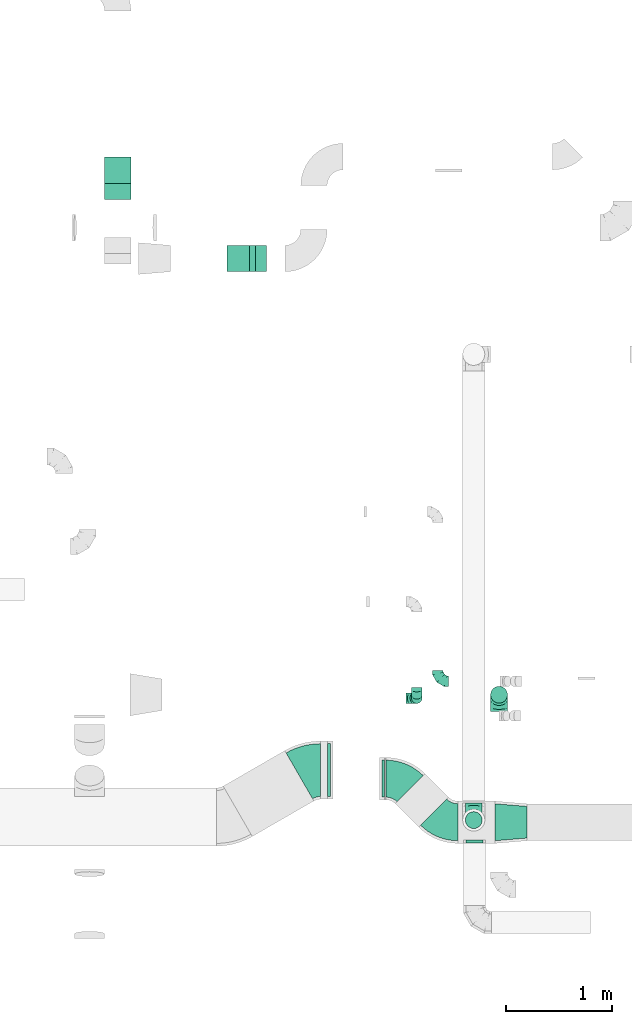
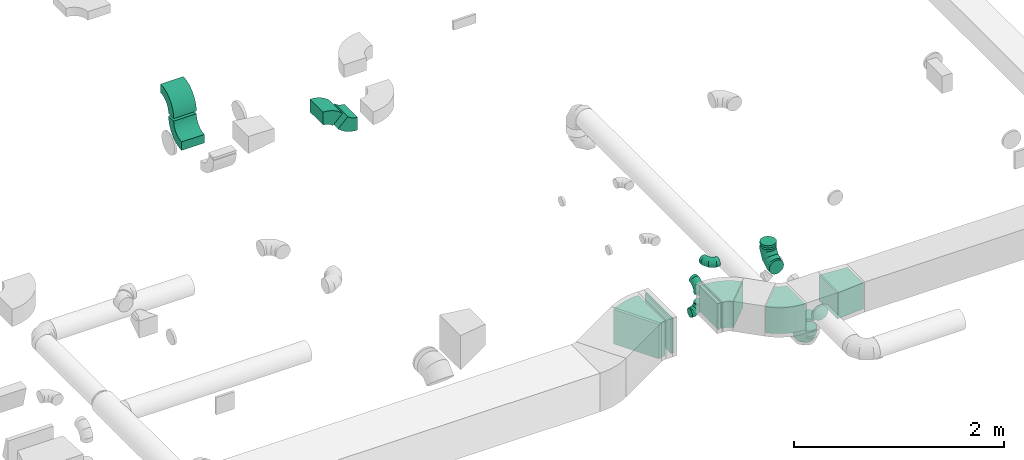
# One storey, part 47 of 62: 18 flow fittings.
"""IFC2X3 building model written with IfcOpenShell, lengths in millimetres."""

from ifc_helpers import new_model, entity, si_unit, converted_unit, derived_unit, direction, frame, frame_2d, origin, origin_2d_with_axis, place, context, subcontext, project, spatial, polyline, circle_curve, parameter, trimmed, segment, composite_curve, rectangle, outline, extrude, faceted_brep, source, transform, mapped, material, type_object, type_shapes, element, save


model = new_model("IFC2X3")

# Units and contexts
model_context = context("Model", 3, precision=0.01, world=origin(), true_north=direction((6.12303176911189e-17, 1.0)))
body_context = subcontext(model_context, "Body", "Model", "MODEL_VIEW")
ifc_project = project(units=[si_unit("LENGTHUNIT", "METRE", prefix="MILLI"), si_unit("AREAUNIT", "SQUARE_METRE"), si_unit("VOLUMEUNIT", "CUBIC_METRE"), converted_unit("PLANEANGLEUNIT", "DEGREE", entity("IfcRatioMeasure", 0.0174532925199433), si_unit("PLANEANGLEUNIT", "RADIAN"), dimensions=[0, 0, 0, 0, 0, 0, 0]), si_unit("MASSUNIT", "GRAM", prefix="KILO"), derived_unit("MASSDENSITYUNIT", [(si_unit("MASSUNIT", "GRAM", prefix="KILO"), 1), (si_unit("LENGTHUNIT", "METRE"), -3)]), derived_unit("MOMENTOFINERTIAUNIT", [(si_unit("LENGTHUNIT", "METRE"), 4)]), si_unit("TIMEUNIT", "SECOND"), si_unit("FREQUENCYUNIT", "HERTZ"), si_unit("THERMODYNAMICTEMPERATUREUNIT", "DEGREE_CELSIUS"), derived_unit("THERMALTRANSMITTANCEUNIT", [(si_unit("MASSUNIT", "GRAM", prefix="KILO"), 1), (si_unit("THERMODYNAMICTEMPERATUREUNIT", "KELVIN"), -1), (si_unit("TIMEUNIT", "SECOND"), -3)]), derived_unit("VOLUMETRICFLOWRATEUNIT", [(si_unit("LENGTHUNIT", "METRE"), 3), (si_unit("TIMEUNIT", "SECOND"), -1)]), derived_unit("MASSFLOWRATEUNIT", [(si_unit("MASSUNIT", "GRAM", prefix="KILO"), 1), (si_unit("TIMEUNIT", "SECOND"), -1)]), derived_unit("ROTATIONALFREQUENCYUNIT", [(si_unit("TIMEUNIT", "SECOND"), -1)]), si_unit("ELECTRICCURRENTUNIT", "AMPERE"), si_unit("ELECTRICVOLTAGEUNIT", "VOLT"), si_unit("POWERUNIT", "WATT"), si_unit("FORCEUNIT", "NEWTON", prefix="KILO"), si_unit("ILLUMINANCEUNIT", "LUX"), si_unit("LUMINOUSFLUXUNIT", "LUMEN"), si_unit("LUMINOUSINTENSITYUNIT", "CANDELA"), derived_unit("USERDEFINED", [(si_unit("MASSUNIT", "GRAM", prefix="KILO"), -1), (si_unit("LENGTHUNIT", "METRE"), -2), (si_unit("TIMEUNIT", "SECOND"), 3), (si_unit("LUMINOUSFLUXUNIT", "LUMEN"), 1)]), derived_unit("LINEARVELOCITYUNIT", [(si_unit("LENGTHUNIT", "METRE"), 1), (si_unit("TIMEUNIT", "SECOND"), -1)]), si_unit("PRESSUREUNIT", "PASCAL"), derived_unit("USERDEFINED", [(si_unit("LENGTHUNIT", "METRE"), -2), (si_unit("MASSUNIT", "GRAM", prefix="KILO"), 1), (si_unit("TIMEUNIT", "SECOND"), -2)]), derived_unit("LINEARFORCEUNIT", [(si_unit("MASSUNIT", "GRAM", prefix="KILO"), 1), (si_unit("LENGTHUNIT", "METRE"), 1), (si_unit("TIMEUNIT", "SECOND"), -2), (si_unit("LENGTHUNIT", "METRE"), -1)]), derived_unit("PLANARFORCEUNIT", [(si_unit("MASSUNIT", "GRAM", prefix="KILO"), 1), (si_unit("LENGTHUNIT", "METRE"), 1), (si_unit("TIMEUNIT", "SECOND"), -2), (si_unit("LENGTHUNIT", "METRE"), -2)])], contexts=[model_context])

# Site, building, storey
site_placement = place(None, origin())
site = spatial("IfcSite", under=ifc_project, at=site_placement, CompositionType="ELEMENT")
building_placement = place(site_placement, origin())
building = spatial("IfcBuilding", under=site, at=building_placement, CompositionType="ELEMENT")
storey_placement = place(building_placement, frame((0.0, 0.0, 24000.0)))
storey = spatial("IfcBuildingStorey", under=building, at=storey_placement, CompositionType="ELEMENT", Elevation=24000.0)

# Flow fittings
ifc_material = material()
duct_fitting_type_1 = type_object("IfcDuctFittingType", PredefinedType="NOTDEFINED", material=ifc_material)
shared_shape_1 = source(origin(), body_context, "Body", "SweptSolid", [
    extrude(outline(polyline([(-164.01, -161.94), (137.03, -161.94), (161.94, 137.03), (-134.95, 186.85), (-164.01, -161.94)])), frame((150.0, 0.0, -150.0), z_axis=(0.0, 0.0, 1.0), x_axis=(0.99654575824488, 0.0830454798537382, 0.0)), (0.0, 0.0, 1.0), 300.0),
])
type_shapes(duct_fitting_type_1, [shared_shape_1])
flow_fitting_1_placement = place(storey_placement, frame((60891.73, 8875.02, 3600.0)))
element("IfcFlowFitting", 1, at=flow_fitting_1_placement, inside=storey, type_object=duct_fitting_type_1, material=ifc_material, context=body_context, shape_type="MappedRepresentation", body=[
    mapped(shared_shape_1, transform((0.0, 0.0, 0.0), scale=1.0)),
])
duct_fitting_type_2 = type_object("IfcDuctFittingType", PredefinedType="NOTDEFINED", material=ifc_material)
shared_shape_2 = source(origin(), body_context, "Body", "SweptSolid", [
    extrude(rectangle(XDim=26.0960000000005, YDim=300.0, at=origin_2d_with_axis()), frame((6.95, 0.0, -175.0)), (0.0, 0.0, 1.0), 350.0),
])
type_shapes(duct_fitting_type_2, [shared_shape_2])
flow_fitting_2_placement = place(storey_placement, frame((59825.64, 9288.12, 3600.0), z_axis=(0.0, -1.0, 0.0), x_axis=(1.0, 0.0, 0.0)))
element("IfcFlowFitting", 2, at=flow_fitting_2_placement, inside=storey, type_object=duct_fitting_type_2, material=ifc_material, context=body_context, shape_type="MappedRepresentation", body=[
    mapped(shared_shape_2, transform((0.0, 0.0, 0.0), scale=1.0)),
])
duct_fitting_type_3 = type_object("IfcDuctFittingType", PredefinedType="NOTDEFINED", material=ifc_material)
shared_shape_3 = source(origin(), body_context, "Body", "SweptSolid", [
    extrude(rectangle(XDim=26.0960000000006, YDim=400.0, at=origin_2d_with_axis()), frame((6.95, 0.0, -250.0)), (0.0, 0.0, 1.0), 500.0),
])
type_shapes(duct_fitting_type_3, [shared_shape_3])
flow_fitting_3_placement = place(storey_placement, frame((59325.64, 9368.57, 3550.0), z_axis=(0.0, 1.0, 0.0), x_axis=(-1.0, 0.0, 0.0)))
element("IfcFlowFitting", 3, at=flow_fitting_3_placement, inside=storey, type_object=duct_fitting_type_3, material=ifc_material, context=body_context, shape_type="MappedRepresentation", body=[
    mapped(shared_shape_3, transform((0.0, 0.0, 0.0), scale=1.0)),
])
duct_fitting_type_4 = type_object("IfcDuctFittingType", PredefinedType="NOTDEFINED", material=ifc_material)
shared_shape_4 = source(origin(), body_context, "Body", "Brep", [
    faceted_brep([(-160.0, 0.0, -80.0), (-160.0, -20.71, -77.27), (-160.0, -40.0, -69.28), (-160.0, -56.57, -56.57), (-160.0, -69.28, -40.0), (-160.0, -77.27, -20.71), (-160.0, -80.0, 0.0), (-160.0, -77.27, 20.71), (-160.0, -69.28, 40.0), (-160.0, -56.57, 56.57), (-160.0, -40.0, 69.28), (-160.0, -20.71, 77.27), (-160.0, 0.0, 80.0), (-160.0, 20.71, 77.27), (-160.0, 40.0, 69.28), (-160.0, 56.57, 56.57), (-160.0, 69.28, 40.0), (-160.0, 77.27, 20.71), (-160.0, 80.0, 0.0), (-160.0, 77.27, -20.71), (-160.0, 69.28, -40.0), (-160.0, 56.57, -56.57), (-160.0, 40.0, -69.28), (-160.0, 20.71, -77.27), (-122.68, 20.71, 77.27), (-127.85, 40.0, 69.28), (-117.13, 0.0, 80.0), (-132.29, 56.57, 56.57), (-137.83, 77.27, 20.71), (-138.56, 80.0, 0.0), (-135.69, 69.28, 40.0), (-135.69, 69.28, -40.0), (-132.29, 56.57, -56.57), (-137.83, 77.27, -20.71), (-122.68, 20.71, -77.27), (-117.13, 0.0, -80.0), (-127.85, 40.0, -69.28), (-111.58, -20.71, -77.27), (-106.41, -40.0, -69.28), (-101.97, -56.57, -56.57), (-98.56, -69.28, -40.0), (-96.42, -77.27, -20.71), (-95.69, -80.0, 0.0), (-96.42, -77.27, 20.71), (-98.56, -69.28, 40.0), (-101.97, -56.57, 56.57), (-106.41, -40.0, 69.28), (-111.58, -20.71, 77.27), (-58.03, 58.03, 77.27), (-72.15, 72.15, 69.28), (-42.87, 42.87, 80.0), (-84.28, 84.28, 56.57), (-93.59, 93.59, 40.0), (-99.44, 99.44, 20.71), (-101.44, 101.44, 0.0), (-99.44, 99.44, -20.71), (-93.59, 93.59, -40.0), (-84.28, 84.28, -56.57), (-58.03, 58.03, -77.27), (-42.87, 42.87, -80.0), (-72.15, 72.15, -69.28), (-27.71, 27.71, -77.27), (-13.59, 13.59, -69.28), (-1.46, 1.46, -56.57), (7.85, -7.85, -40.0), (13.7, -13.7, -20.71), (15.69, -15.69, 0.0), (13.7, -13.7, 20.71), (7.85, -7.85, 40.0), (-1.46, 1.46, 56.57), (-13.59, 13.59, 69.28), (-27.71, 27.71, 77.27), (-20.71, 122.68, 77.27), (-40.0, 127.85, 69.28), (0.0, 117.13, 80.0), (-56.57, 132.29, 56.57), (-69.28, 135.69, 40.0), (-77.27, 137.83, 20.71), (-80.0, 138.56, 0.0), (-77.27, 137.83, -20.71), (-69.28, 135.69, -40.0), (-56.57, 132.29, -56.57), (-20.71, 122.68, -77.27), (0.0, 117.13, -80.0), (-40.0, 127.85, -69.28), (20.71, 111.58, -77.27), (40.0, 106.41, -69.28), (56.57, 101.97, -56.57), (69.28, 98.56, -40.0), (77.27, 96.42, -20.71), (80.0, 95.69, 0.0), (77.27, 96.42, 20.71), (69.28, 98.56, 40.0), (56.57, 101.97, 56.57), (40.0, 106.41, 69.28), (20.71, 111.58, 77.27), (-20.71, 160.0, -77.27), (-40.0, 160.0, -69.28), (-56.57, 160.0, -56.57), (-69.28, 160.0, -40.0), (-77.27, 160.0, -20.71), (-80.0, 160.0, 0.0), (-77.27, 160.0, 20.71), (-69.28, 160.0, 40.0), (-56.57, 160.0, 56.57), (-40.0, 160.0, 69.28), (-20.71, 160.0, 77.27), (0.0, 160.0, 80.0), (20.71, 160.0, 77.27), (40.0, 160.0, 69.28), (56.57, 160.0, 56.57), (69.28, 160.0, 40.0), (77.27, 160.0, 20.71), (80.0, 160.0, 0.0), (77.27, 160.0, -20.71), (69.28, 160.0, -40.0), (56.57, 160.0, -56.57), (40.0, 160.0, -69.28), (20.71, 160.0, -77.27), (0.0, 160.0, -80.0)], [[[0, 1, 2, 3, 4, 5, 6, 7, 8, 9, 10, 11, 12, 13, 14, 15, 16, 17, 18, 19, 20, 21, 22, 23]], [[24, 25, 14, 13]], [[26, 24, 13, 12]], [[14, 25, 27, 15]], [[28, 29, 18, 17]], [[30, 28, 17, 16]], [[15, 27, 30, 16]], [[20, 31, 32, 21]], [[33, 31, 20, 19]], [[18, 29, 33, 19]], [[34, 35, 0, 23]], [[36, 34, 23, 22]], [[32, 36, 22, 21]], [[1, 0, 35, 37]], [[2, 1, 37, 38]], [[3, 2, 38, 39]], [[5, 4, 40, 41]], [[6, 5, 41, 42]], [[39, 40, 4, 3]], [[6, 42, 43, 7]], [[7, 43, 44, 8]], [[8, 44, 45, 9]], [[9, 45, 46, 10]], [[10, 46, 47, 11]], [[26, 12, 11, 47]], [[48, 49, 25, 24]], [[50, 48, 24, 26]], [[27, 25, 49, 51]], [[52, 53, 28, 30]], [[51, 52, 30, 27]], [[29, 28, 53, 54]], [[55, 56, 31, 33]], [[54, 55, 33, 29]], [[32, 31, 56, 57]], [[58, 59, 35, 34]], [[60, 58, 34, 36]], [[57, 60, 36, 32]], [[37, 35, 59, 61]], [[38, 37, 61, 62]], [[39, 38, 62, 63]], [[41, 40, 64, 65]], [[42, 41, 65, 66]], [[63, 64, 40, 39]], [[43, 42, 66, 67]], [[44, 43, 67, 68]], [[68, 69, 45, 44]], [[46, 45, 69, 70]], [[47, 46, 70, 71]], [[26, 47, 71, 50]], [[72, 73, 49, 48]], [[74, 72, 48, 50]], [[51, 49, 73, 75]], [[76, 77, 53, 52]], [[75, 76, 52, 51]], [[54, 53, 77, 78]], [[79, 80, 56, 55]], [[78, 79, 55, 54]], [[57, 56, 80, 81]], [[82, 83, 59, 58]], [[84, 82, 58, 60]], [[81, 84, 60, 57]], [[61, 59, 83, 85]], [[62, 61, 85, 86]], [[63, 62, 86, 87]], [[65, 64, 88, 89]], [[66, 65, 89, 90]], [[87, 88, 64, 63]], [[67, 66, 90, 91]], [[68, 67, 91, 92]], [[92, 93, 69, 68]], [[70, 69, 93, 94]], [[71, 70, 94, 95]], [[50, 71, 95, 74]], [[96, 97, 98, 99, 100, 101, 102, 103, 104, 105, 106, 107, 108, 109, 110, 111, 112, 113, 114, 115, 116, 117, 118, 119]], [[72, 74, 107, 106]], [[73, 72, 106, 105]], [[75, 73, 105, 104]], [[77, 76, 103, 102]], [[78, 77, 102, 101]], [[75, 104, 103, 76]], [[78, 101, 100, 79]], [[79, 100, 99, 80]], [[80, 99, 98, 81]], [[84, 97, 96, 82]], [[82, 96, 119, 83]], [[84, 81, 98, 97]], [[118, 117, 86, 85]], [[119, 118, 85, 83]], [[116, 87, 86, 117]], [[88, 115, 114, 89]], [[89, 114, 113, 90]], [[115, 88, 87, 116]], [[112, 111, 92, 91]], [[113, 112, 91, 90]], [[111, 110, 93, 92]], [[95, 94, 109, 108]], [[74, 95, 108, 107]], [[110, 109, 94, 93]]]),
])
type_shapes(duct_fitting_type_4, [shared_shape_4])
for number, where, z_axis, x_axis in (
    (4, (60928.45, 10082.41, 3300.0), (1.0, 0.0, 0.0), (0.0, 1.0, 0.0)),
    (5, (60688.85, 8895.62, 3160.0), (1.0, 0.0, 0.0), (0.0, 0.0, -1.0)),
):
    element("IfcFlowFitting", number, at=place(storey_placement, frame(where, z_axis=z_axis, x_axis=x_axis)), inside=storey, type_object=duct_fitting_type_4, material=ifc_material, context=body_context, shape_type="MappedRepresentation", body=[
        mapped(shared_shape_4, transform((0.0, 0.0, 0.0), scale=1.0)),
    ])
duct_fitting_type_5 = type_object("IfcDuctFittingType", PredefinedType="NOTDEFINED", material=ifc_material)
shared_shape_5 = source(origin(), body_context, "Body", "Brep", [
    faceted_brep([(-100.0, 0.0, -50.0), (-100.0, -12.94, -48.3), (-100.0, -25.0, -43.3), (-100.0, -35.36, -35.36), (-100.0, -43.3, -25.0), (-100.0, -48.3, -12.94), (-100.0, -50.0, 0.0), (-100.0, -48.3, 12.94), (-100.0, -43.3, 25.0), (-100.0, -35.36, 35.36), (-100.0, -25.0, 43.3), (-100.0, -12.94, 48.3), (-100.0, 0.0, 50.0), (-100.0, 12.94, 48.3), (-100.0, 25.0, 43.3), (-100.0, 35.36, 35.36), (-100.0, 43.3, 25.0), (-100.0, 48.3, 12.94), (-100.0, 50.0, 0.0), (-100.0, 48.3, -12.94), (-100.0, 43.3, -25.0), (-100.0, 35.36, -35.36), (-100.0, 25.0, -43.3), (-100.0, 12.94, -48.3), (-76.67, 12.94, 48.3), (-79.9, 25.0, 43.3), (-73.21, 0.0, 50.0), (-82.68, 35.36, 35.36), (-86.15, 48.3, 12.94), (-86.6, 50.0, 0.0), (-84.81, 43.3, 25.0), (-84.81, 43.3, -25.0), (-82.68, 35.36, -35.36), (-86.15, 48.3, -12.94), (-76.67, 12.94, -48.3), (-73.21, 0.0, -50.0), (-79.9, 25.0, -43.3), (-69.74, -12.94, -48.3), (-66.51, -25.0, -43.3), (-63.73, -35.36, -35.36), (-61.6, -43.3, -25.0), (-60.26, -48.3, -12.94), (-59.81, -50.0, 0.0), (-60.26, -48.3, 12.94), (-61.6, -43.3, 25.0), (-63.73, -35.36, 35.36), (-66.51, -25.0, 43.3), (-69.74, -12.94, 48.3), (-36.27, 36.27, 48.3), (-45.1, 45.1, 43.3), (-26.79, 26.79, 50.0), (-52.68, 52.68, 35.36), (-58.49, 58.49, 25.0), (-62.15, 62.15, 12.94), (-63.4, 63.4, 0.0), (-62.15, 62.15, -12.94), (-58.49, 58.49, -25.0), (-52.68, 52.68, -35.36), (-36.27, 36.27, -48.3), (-26.79, 26.79, -50.0), (-45.1, 45.1, -43.3), (-17.32, 17.32, -48.3), (-8.49, 8.49, -43.3), (-0.91, 0.91, -35.36), (4.9, -4.9, -25.0), (8.56, -8.56, -12.94), (9.81, -9.81, 0.0), (8.56, -8.56, 12.94), (4.9, -4.9, 25.0), (-0.91, 0.91, 35.36), (-8.49, 8.49, 43.3), (-17.32, 17.32, 48.3), (-12.94, 76.67, 48.3), (-25.0, 79.9, 43.3), (0.0, 73.21, 50.0), (-35.36, 82.68, 35.36), (-43.3, 84.81, 25.0), (-48.3, 86.15, 12.94), (-50.0, 86.6, 0.0), (-48.3, 86.15, -12.94), (-43.3, 84.81, -25.0), (-35.36, 82.68, -35.36), (-12.94, 76.67, -48.3), (0.0, 73.21, -50.0), (-25.0, 79.9, -43.3), (12.94, 69.74, -48.3), (25.0, 66.51, -43.3), (35.36, 63.73, -35.36), (43.3, 61.6, -25.0), (48.3, 60.26, -12.94), (50.0, 59.81, 0.0), (48.3, 60.26, 12.94), (43.3, 61.6, 25.0), (35.36, 63.73, 35.36), (25.0, 66.51, 43.3), (12.94, 69.74, 48.3), (-12.94, 100.0, -48.3), (-25.0, 100.0, -43.3), (-35.36, 100.0, -35.36), (-43.3, 100.0, -25.0), (-48.3, 100.0, -12.94), (-50.0, 100.0, 0.0), (-48.3, 100.0, 12.94), (-43.3, 100.0, 25.0), (-35.36, 100.0, 35.36), (-25.0, 100.0, 43.3), (-12.94, 100.0, 48.3), (0.0, 100.0, 50.0), (12.94, 100.0, 48.3), (25.0, 100.0, 43.3), (35.36, 100.0, 35.36), (43.3, 100.0, 25.0), (48.3, 100.0, 12.94), (50.0, 100.0, 0.0), (48.3, 100.0, -12.94), (43.3, 100.0, -25.0), (35.36, 100.0, -35.36), (25.0, 100.0, -43.3), (12.94, 100.0, -48.3), (0.0, 100.0, -50.0)], [[[0, 1, 2, 3, 4, 5, 6, 7, 8, 9, 10, 11, 12, 13, 14, 15, 16, 17, 18, 19, 20, 21, 22, 23]], [[24, 25, 14, 13]], [[26, 24, 13, 12]], [[14, 25, 27, 15]], [[28, 29, 18, 17]], [[30, 28, 17, 16]], [[15, 27, 30, 16]], [[20, 31, 32, 21]], [[33, 31, 20, 19]], [[18, 29, 33, 19]], [[34, 35, 0, 23]], [[36, 34, 23, 22]], [[32, 36, 22, 21]], [[2, 1, 37, 38]], [[3, 2, 38, 39]], [[0, 35, 37, 1]], [[5, 4, 40, 41]], [[6, 5, 41, 42]], [[3, 39, 40, 4]], [[6, 42, 43, 7]], [[7, 43, 44, 8]], [[8, 44, 45, 9]], [[10, 46, 47, 11]], [[11, 47, 26, 12]], [[10, 9, 45, 46]], [[48, 49, 25, 24]], [[50, 48, 24, 26]], [[27, 25, 49, 51]], [[52, 53, 28, 30]], [[51, 52, 30, 27]], [[29, 28, 53, 54]], [[55, 56, 31, 33]], [[54, 55, 33, 29]], [[57, 32, 31, 56]], [[58, 59, 35, 34]], [[60, 58, 34, 36]], [[57, 60, 36, 32]], [[37, 35, 59, 61]], [[38, 37, 61, 62]], [[39, 38, 62, 63]], [[41, 40, 64, 65]], [[42, 41, 65, 66]], [[63, 64, 40, 39]], [[43, 42, 66, 67]], [[44, 43, 67, 68]], [[68, 69, 45, 44]], [[46, 45, 69, 70]], [[47, 46, 70, 71]], [[26, 47, 71, 50]], [[72, 73, 49, 48]], [[74, 72, 48, 50]], [[51, 49, 73, 75]], [[76, 77, 53, 52]], [[75, 76, 52, 51]], [[54, 53, 77, 78]], [[79, 80, 56, 55]], [[78, 79, 55, 54]], [[81, 57, 56, 80]], [[82, 83, 59, 58]], [[84, 82, 58, 60]], [[81, 84, 60, 57]], [[61, 59, 83, 85]], [[62, 61, 85, 86]], [[63, 62, 86, 87]], [[65, 64, 88, 89]], [[66, 65, 89, 90]], [[87, 88, 64, 63]], [[67, 66, 90, 91]], [[68, 67, 91, 92]], [[92, 93, 69, 68]], [[70, 69, 93, 94]], [[71, 70, 94, 95]], [[50, 71, 95, 74]], [[96, 97, 98, 99, 100, 101, 102, 103, 104, 105, 106, 107, 108, 109, 110, 111, 112, 113, 114, 115, 116, 117, 118, 119]], [[72, 74, 107, 106]], [[73, 72, 106, 105]], [[75, 73, 105, 104]], [[77, 76, 103, 102]], [[78, 77, 102, 101]], [[75, 104, 103, 76]], [[78, 101, 100, 79]], [[79, 100, 99, 80]], [[80, 99, 98, 81]], [[96, 119, 83, 82]], [[97, 96, 82, 84]], [[84, 81, 98, 97]], [[83, 119, 118, 85]], [[85, 118, 117, 86]], [[86, 117, 116, 87]], [[88, 115, 114, 89]], [[89, 114, 113, 90]], [[87, 116, 115, 88]], [[91, 90, 113, 112]], [[92, 91, 112, 111]], [[93, 92, 111, 110]], [[95, 94, 109, 108]], [[74, 95, 108, 107]], [[110, 109, 94, 93]]]),
])
type_shapes(duct_fitting_type_5, [shared_shape_5])
for number, where, z_axis, x_axis in (
    (6, (60349.74, 10209.98, 3360.0), (0.0, 0.0, 1.0), (0.0, -1.0, 0.0)),
    (7, (60149.52, 10049.93, 3000.0), (0.0, -1.0, 0.0), (1.0, 0.0, 0.0)),
    (8, (60149.52, 10049.93, 3300.0), (-1.0, 0.0, 0.0), (0.0, 0.0, 1.0)),
):
    element("IfcFlowFitting", number, at=place(storey_placement, frame(where, z_axis=z_axis, x_axis=x_axis)), inside=storey, type_object=duct_fitting_type_5, material=ifc_material, context=body_context, shape_type="MappedRepresentation", body=[
        mapped(shared_shape_5, transform((0.0, 0.0, 0.0), scale=1.0)),
    ])
duct_fitting_type_6 = type_object("IfcDuctFittingType", PredefinedType="NOTDEFINED", material=ifc_material)
shared_shape_6 = source(origin(), body_context, "Body", "Brep", [
    faceted_brep([(20.0, 0.0, -80.0), (20.0, 20.71, -77.27), (20.0, 40.0, -69.28), (20.0, 56.57, -56.57), (20.0, 69.28, -40.0), (20.0, 77.27, -20.71), (20.0, 80.0, 0.0), (20.0, 77.27, 20.71), (20.0, 69.28, 40.0), (20.0, 56.57, 56.57), (20.0, 40.0, 69.28), (20.0, 20.71, 77.27), (20.0, 0.0, 80.0), (20.0, -20.71, 77.27), (20.0, -40.0, 69.28), (20.0, -56.57, 56.57), (20.0, -69.28, 40.0), (20.0, -77.27, 20.71), (20.0, -80.0, 0.0), (20.0, -77.27, -20.71), (20.0, -69.28, -40.0), (20.0, -56.57, -56.57), (20.0, -40.0, -69.28), (20.0, -20.71, -77.27), (0.0, 0.0, 80.0), (-6.1, 0.0, 80.0), (-6.1, -20.71, 77.27), (0.0, -20.71, 77.27), (-6.1, -40.0, 69.28), (0.0, -40.0, 69.28), (0.0, -56.57, 56.57), (-6.1, -56.57, 56.57), (0.0, -69.28, 40.0), (-6.1, -69.28, 40.0), (-6.1, -77.27, 20.71), (0.0, -77.27, 20.71), (-6.1, -80.0, 0.0), (0.0, -80.0, 0.0), (-6.1, -77.27, -20.71), (0.0, -77.27, -20.71), (-6.1, -69.28, -40.0), (0.0, -69.28, -40.0), (0.0, -56.57, -56.57), (-6.1, -56.57, -56.57), (0.0, -40.0, -69.28), (-6.1, -40.0, -69.28), (-6.1, -20.71, -77.27), (0.0, -20.71, -77.27), (-6.1, 0.0, -80.0), (0.0, 0.0, -80.0), (-6.1, 20.71, -77.27), (0.0, 20.71, -77.27), (-6.1, 40.0, -69.28), (0.0, 40.0, -69.28), (0.0, 56.57, -56.57), (-6.1, 56.57, -56.57), (0.0, 69.28, -40.0), (-6.1, 69.28, -40.0), (-6.1, 77.27, -20.71), (0.0, 77.27, -20.71), (-6.1, 80.0, 0.0), (0.0, 80.0, 0.0), (-6.1, 77.27, 20.71), (0.0, 77.27, 20.71), (-6.1, 69.28, 40.0), (0.0, 69.28, 40.0), (0.0, 56.57, 56.57), (-6.1, 56.57, 56.57), (0.0, 40.0, 69.28), (-6.1, 40.0, 69.28), (-6.1, 20.71, 77.27), (0.0, 20.71, 77.27)], [[[0, 1, 2, 3, 4, 5, 6, 7, 8, 9, 10, 11, 12, 13, 14, 15, 16, 17, 18, 19, 20, 21, 22, 23]], [[13, 12, 24, 25, 26, 27]], [[14, 13, 27, 26, 28, 29]], [[30, 15, 14, 29, 28, 31]], [[17, 16, 32, 33, 34, 35]], [[18, 17, 35, 34, 36, 37]], [[32, 16, 15, 30, 31, 33]], [[19, 18, 37, 36, 38, 39]], [[20, 19, 39, 38, 40, 41]], [[42, 21, 20, 41, 40, 43]], [[23, 22, 44, 45, 46, 47]], [[0, 23, 47, 46, 48, 49]], [[44, 22, 21, 42, 43, 45]], [[1, 0, 49, 48, 50, 51]], [[2, 1, 51, 50, 52, 53]], [[54, 3, 2, 53, 52, 55]], [[5, 4, 56, 57, 58, 59]], [[6, 5, 59, 58, 60, 61]], [[56, 4, 3, 54, 55, 57]], [[7, 6, 61, 60, 62, 63]], [[8, 7, 63, 62, 64, 65]], [[66, 9, 8, 65, 64, 67]], [[11, 10, 68, 69, 70, 71]], [[12, 11, 71, 70, 25, 24]], [[68, 10, 9, 66, 67, 69]], [[46, 45, 43, 40, 38, 36, 34, 33, 31, 28, 26, 25, 70, 69, 67, 64, 62, 60, 58, 57, 55, 52, 50, 48]]]),
])
type_shapes(duct_fitting_type_6, [shared_shape_6])
for number, where, z_axis, x_axis in (
    (9, (60928.45, 10082.41, 3500.0), (0.0, -1.0, 0.0), (0.0, 0.0, -1.0)),
    (10, (60696.21, 8700.02, 3600.0), (0.0, 0.0, -1.0), (0.0, -1.0, 0.0)),
):
    element("IfcFlowFitting", number, at=place(storey_placement, frame(where, z_axis=z_axis, x_axis=x_axis)), inside=storey, type_object=duct_fitting_type_6, material=ifc_material, context=body_context, shape_type="MappedRepresentation", body=[
        mapped(shared_shape_6, transform((0.0, 0.0, 0.0), scale=1.0)),
    ])
duct_fitting_type_7 = type_object("IfcDuctFittingType", PredefinedType="NOTDEFINED", material=ifc_material)
shared_shape_7 = source(origin(), body_context, "Body", "Brep", [
    faceted_brep([(20.0, 20.71, -77.27), (20.0, 40.0, -69.28), (20.0, 56.57, -56.57), (20.0, 69.28, -40.0), (20.0, 77.27, -20.71), (20.0, 80.0, 0.0), (20.0, 77.27, 20.71), (20.0, 69.28, 40.0), (20.0, 56.57, 56.57), (20.0, 40.0, 69.28), (20.0, 20.71, 77.27), (20.0, 0.0, 80.0), (20.0, -20.71, 77.27), (20.0, -40.0, 69.28), (20.0, -56.57, 56.57), (20.0, -69.28, 40.0), (20.0, -77.27, 20.71), (20.0, -80.0, 0.0), (20.0, -77.27, -20.71), (20.0, -69.28, -40.0), (20.0, -56.57, -56.57), (20.0, -40.0, -69.28), (20.0, -20.71, -77.27), (20.0, 0.0, -80.0), (0.0, 0.0, 80.0), (0.0, 20.71, 77.27), (-6.1, 20.71, 77.27), (-6.1, 0.0, 80.0), (0.0, 40.0, 69.28), (-6.1, 40.0, 69.28), (0.0, 56.57, 56.57), (-6.1, 56.57, 56.57), (0.0, 69.28, 40.0), (0.0, 77.27, 20.71), (-6.1, 77.27, 20.71), (-6.1, 69.28, 40.0), (0.0, 80.0, 0.0), (-6.1, 80.0, 0.0), (0.0, 77.27, -20.71), (-6.1, 77.27, -20.71), (0.0, 69.28, -40.0), (-6.1, 69.28, -40.0), (0.0, 56.57, -56.57), (-6.1, 56.57, -56.57), (0.0, 40.0, -69.28), (0.0, 20.71, -77.27), (-6.1, 20.71, -77.27), (-6.1, 40.0, -69.28), (0.0, 0.0, -80.0), (-6.1, 0.0, -80.0), (0.0, -20.71, -77.27), (-6.1, -20.71, -77.27), (0.0, -40.0, -69.28), (-6.1, -40.0, -69.28), (0.0, -56.57, -56.57), (-6.1, -56.57, -56.57), (0.0, -69.28, -40.0), (0.0, -77.27, -20.71), (-6.1, -77.27, -20.71), (-6.1, -69.28, -40.0), (0.0, -80.0, 0.0), (-6.1, -80.0, 0.0), (0.0, -77.27, 20.71), (-6.1, -77.27, 20.71), (0.0, -69.28, 40.0), (-6.1, -69.28, 40.0), (0.0, -56.57, 56.57), (-6.1, -56.57, 56.57), (0.0, -40.0, 69.28), (0.0, -20.71, 77.27), (-6.1, -20.71, 77.27), (-6.1, -40.0, 69.28)], [[[0, 1, 2, 3, 4, 5, 6, 7, 8, 9, 10, 11, 12, 13, 14, 15, 16, 17, 18, 19, 20, 21, 22, 23]], [[24, 11, 10, 25, 26, 27]], [[25, 10, 9, 28, 29, 26]], [[28, 9, 8, 30, 31, 29]], [[32, 7, 6, 33, 34, 35]], [[33, 6, 5, 36, 37, 34]], [[30, 8, 7, 32, 35, 31]], [[36, 5, 4, 38, 39, 37]], [[38, 4, 3, 40, 41, 39]], [[40, 3, 2, 42, 43, 41]], [[44, 1, 0, 45, 46, 47]], [[45, 0, 23, 48, 49, 46]], [[42, 2, 1, 44, 47, 43]], [[48, 23, 22, 50, 51, 49]], [[50, 22, 21, 52, 53, 51]], [[52, 21, 20, 54, 55, 53]], [[56, 19, 18, 57, 58, 59]], [[57, 18, 17, 60, 61, 58]], [[54, 20, 19, 56, 59, 55]], [[60, 17, 16, 62, 63, 61]], [[62, 16, 15, 64, 65, 63]], [[64, 15, 14, 66, 67, 65]], [[68, 13, 12, 69, 70, 71]], [[69, 12, 11, 24, 27, 70]], [[66, 14, 13, 68, 71, 67]], [[49, 51, 53, 55, 59, 58, 61, 63, 65, 67, 71, 70, 27, 26, 29, 31, 35, 34, 37, 39, 41, 43, 47, 46]]]),
])
type_shapes(duct_fitting_type_7, [shared_shape_7])
flow_fitting_4_placement = place(storey_placement, frame((60688.85, 8895.62, 3450.0), z_axis=(0.0, -1.0, 0.0), x_axis=(0.0, 0.0, -1.0)))
element("IfcFlowFitting", 11, at=flow_fitting_4_placement, inside=storey, type_object=duct_fitting_type_7, material=ifc_material, context=body_context, shape_type="MappedRepresentation", body=[
    mapped(shared_shape_7, transform((0.0, 0.0, 0.0), scale=1.0)),
])
duct_fitting_type_8 = type_object("IfcDuctFittingType", PredefinedType="NOTDEFINED", material=ifc_material)
shared_shape_8 = source(origin(), body_context, "Body", "SweptSolid", [
    extrude(outline(composite_curve([segment(polyline([(-107.95, -79.55), (42.05, -79.55)]), True, "CONTINUOUS"), segment(trimmed(circle_curve(frame_2d((192.05, -79.55), x_axis=(-0.707106781186546, 0.707106781186546)), 150.0), [parameter(0.0)], [parameter(45.0)], True, "PARAMETER"), False, "CONTINUOUS"), segment(polyline([(85.98, 26.52), (-20.08, 132.58)]), True, "CONTINUOUS"), segment(trimmed(circle_curve(frame_2d((192.05, -79.55), x_axis=(-0.707106781186546, 0.707106781186546)), 300.0), [parameter(0.0)], [parameter(45.0)], True, "PARAMETER"), True, "CONTINUOUS")], self_intersect=False)), frame((-13.65, 32.95, -125.0), z_axis=(0.0, 0.0, 1.0), x_axis=(-0.707106781186547, 0.707106781186548, 0.0)), (0.0, 0.0, 1.0), 250.0),
])
type_shapes(duct_fitting_type_8, [shared_shape_8])
for number, where, z_axis, x_axis in (
    (12, (58445.82, 14212.02, 3400.0), (0.0, 1.0, 0.0), (1.0, 0.0, 0.0)),
    (13, (58635.82, 14212.02, 3210.0), (0.0, -1.0, 0.0), (0.707106781186271, 0.0, -0.707106781186824)),
):
    element("IfcFlowFitting", number, at=place(storey_placement, frame(where, z_axis=z_axis, x_axis=x_axis)), inside=storey, type_object=duct_fitting_type_8, material=ifc_material, context=body_context, shape_type="MappedRepresentation", body=[
        mapped(shared_shape_8, transform((0.0, 0.0, 0.0), scale=1.0)),
    ])
duct_fitting_type_9 = type_object("IfcDuctFittingType", PredefinedType="NOTDEFINED", material=ifc_material)
shared_shape_9 = source(origin(), body_context, "Body", "SweptSolid", [
    extrude(outline(composite_curve([segment(polyline([(-150.0, -100.0), (-50.0, -100.0)]), True, "CONTINUOUS"), segment(trimmed(circle_curve(frame_2d((100.0, -100.0), x_axis=(0.0, 1.0)), 150.0), [parameter(0.0)], [parameter(90.0000000000001)], True, "PARAMETER"), False, "CONTINUOUS"), segment(polyline([(100.0, 50.0), (100.0, 150.0)]), True, "CONTINUOUS"), segment(trimmed(circle_curve(frame_2d((100.0, -100.0), x_axis=(0.0, 1.0)), 250.0), [parameter(0.0)], [parameter(90.0000000000001)], True, "PARAMETER"), True, "CONTINUOUS")], self_intersect=False)), frame((-100.0, 100.0, -125.0), z_axis=(0.0, 0.0, 1.0), x_axis=(-1.0, 0.0, 0.0)), (0.0, 0.0, 1.0), 250.0),
])
type_shapes(duct_fitting_type_9, [shared_shape_9])
for number, where, z_axis, x_axis in (
    (14, (57317.89, 14972.02, 3500.0), (1.0, 0.0, 0.0), (0.0, -1.0, 0.0)),
    (15, (57317.89, 14972.02, 3070.0), (-1.0, 0.0, 0.0), (0.0, 0.0, -1.0)),
):
    element("IfcFlowFitting", number, at=place(storey_placement, frame(where, z_axis=z_axis, x_axis=x_axis)), inside=storey, type_object=duct_fitting_type_9, material=ifc_material, context=body_context, shape_type="MappedRepresentation", body=[
        mapped(shared_shape_9, transform((0.0, 0.0, 0.0), scale=1.0)),
    ])
duct_fitting_type_10 = type_object("IfcDuctFittingType", PredefinedType="NOTDEFINED", material=ifc_material)
shared_shape_10 = source(origin(), body_context, "Body", "SweptSolid", [
    extrude(outline(composite_curve([segment(polyline([(-276.79, -100.0), (223.21, -100.0)]), True, "CONTINUOUS"), segment(trimmed(circle_curve(frame_2d((373.21, -100.0), x_axis=(-0.866025403784437, 0.499999999999998)), 150.0), [parameter(0.0)], [parameter(29.9999999999999)], True, "PARAMETER"), False, "CONTINUOUS"), segment(polyline([(243.3, -25.0), (-189.71, 225.0)]), True, "CONTINUOUS"), segment(trimmed(circle_curve(frame_2d((373.21, -100.0), x_axis=(-0.866025403784437, 0.499999999999998)), 650.0), [parameter(0.0)], [parameter(29.9999999999999)], True, "PARAMETER"), True, "CONTINUOUS")], self_intersect=False)), frame((-7.18, 26.79, -200.0), z_axis=(0.0, 0.0, 1.0), x_axis=(-0.499999999999999, 0.866025403784439, 0.0)), (0.0, 0.0, 1.0), 400.0),
])
type_shapes(duct_fitting_type_10, [shared_shape_10])
flow_fitting_5_placement = place(storey_placement, frame((59130.06, 9368.57, 3550.0), z_axis=(0.0, 0.0, 1.0), x_axis=(-1.0, 0.0, 0.0)))
element("IfcFlowFitting", 16, at=flow_fitting_5_placement, inside=storey, type_object=duct_fitting_type_10, material=ifc_material, context=body_context, shape_type="MappedRepresentation", body=[
    mapped(shared_shape_10, transform((0.0, 0.0, 0.0), scale=1.0)),
])
duct_fitting_type_11 = type_object("IfcDuctFittingType", PredefinedType="NOTDEFINED", material=ifc_material)
shared_shape_11 = source(origin(), body_context, "Body", "SweptSolid", [
    extrude(outline(composite_curve([segment(polyline([(-222.6, -114.9), (127.4, -114.9)]), True, "CONTINUOUS"), segment(trimmed(circle_curve(frame_2d((277.4, -114.9), x_axis=(-0.707106781186553, 0.707106781186546)), 150.0), [parameter(0.0)], [parameter(45.0)], True, "PARAMETER"), False, "CONTINUOUS"), segment(polyline([(171.34, -8.84), (-76.15, 238.65)]), True, "CONTINUOUS"), segment(trimmed(circle_curve(frame_2d((277.4, -114.9), x_axis=(-0.707106781186553, 0.707106781186546)), 500.0), [parameter(0.0)], [parameter(45.0)], True, "PARAMETER"), True, "CONTINUOUS")], self_intersect=False)), frame((-19.71, 47.6, -150.0), z_axis=(0.0, 0.0, 1.0), x_axis=(-0.707106781186547, 0.707106781186548, 0.0)), (0.0, 0.0, 1.0), 300.0),
])
type_shapes(duct_fitting_type_11, [shared_shape_11])
for number, where, z_axis, x_axis in (
    (17, (60404.83, 8875.02, 3600.0), (0.0, 0.0, 1.0), (0.707106781186545, -0.70710678118655, 0.0)),
    (18, (59991.73, 9288.12, 3600.0), (0.0, 0.0, 1.0), (-0.707106781186531, 0.707106781186564, 0.0)),
):
    element("IfcFlowFitting", number, at=place(storey_placement, frame(where, z_axis=z_axis, x_axis=x_axis)), inside=storey, type_object=duct_fitting_type_11, material=ifc_material, context=body_context, shape_type="MappedRepresentation", body=[
        mapped(shared_shape_11, transform((0.0, 0.0, 0.0), scale=1.0)),
    ])

save(model, "model.ifc")
